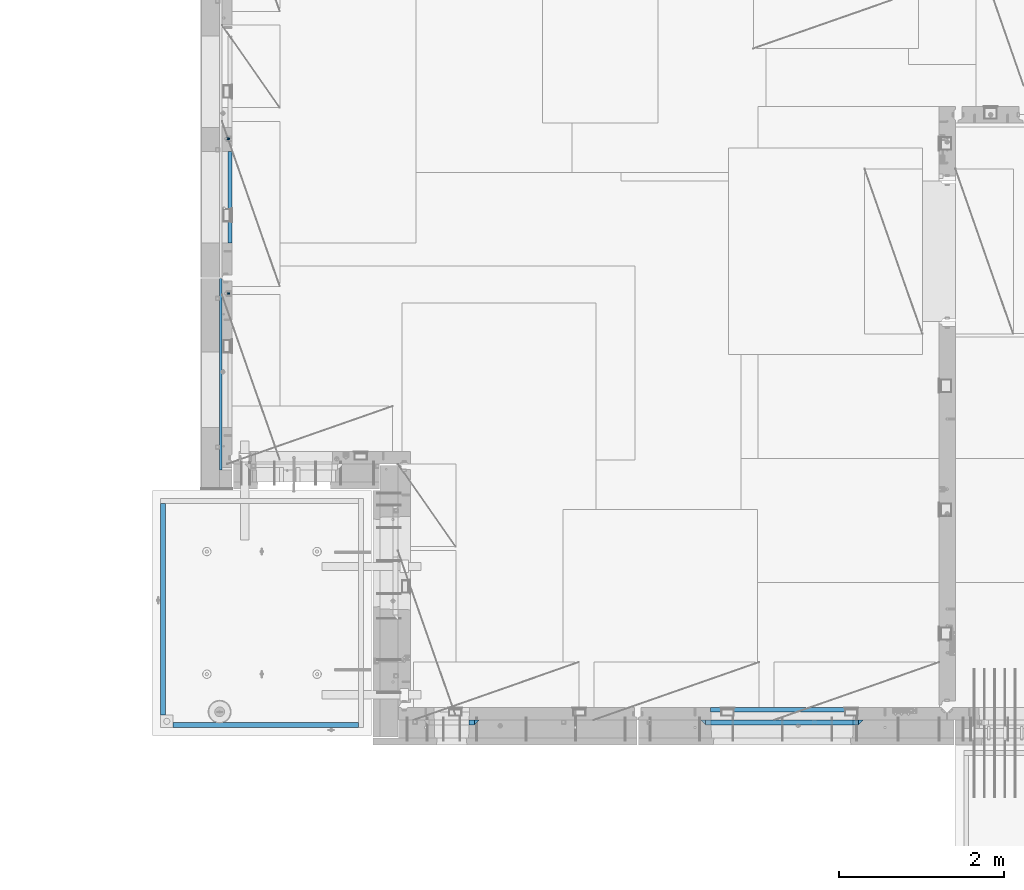
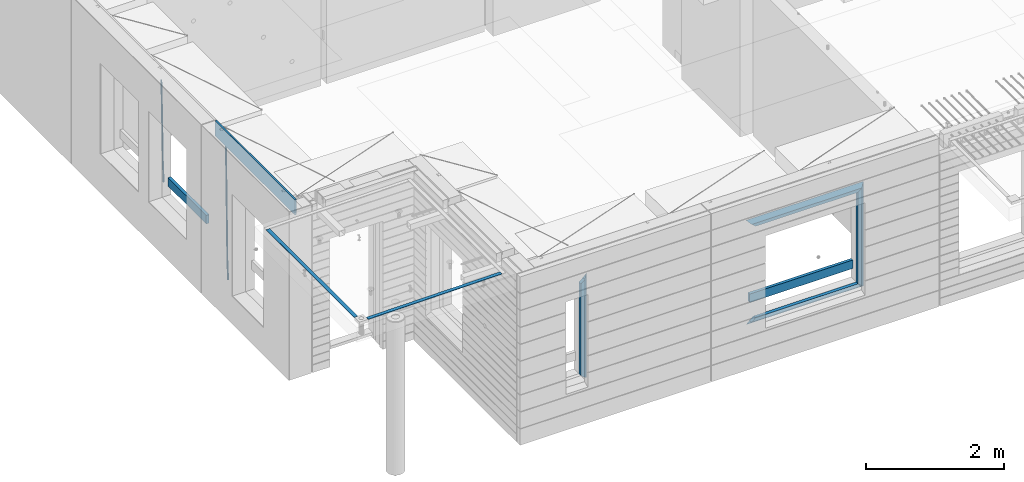
# One storey, part 91 of 352: 15 beams, 5 elements without a shape of their own.
"""IFC2X3 building model written with IfcOpenShell, lengths in millimetres."""

from ifc_helpers import new_model, si_unit, frame, origin_with_axes, place, context, subcontext, project, spatial, faceted_brep, material, type_object, element, aggregate, save


model = new_model("IFC2X3")

# Units and contexts
model_context = context("Model", 3, precision=1e-05, world=origin_with_axes())
body_context = subcontext(model_context, "Body", "Model", "MODEL_VIEW")
ifc_project = project(units=[si_unit("LENGTHUNIT", "METRE", prefix="MILLI"), si_unit("AREAUNIT", "SQUARE_METRE"), si_unit("VOLUMEUNIT", "CUBIC_METRE"), si_unit("MASSUNIT", "GRAM", prefix="KILO"), si_unit("TIMEUNIT", "SECOND"), si_unit("PLANEANGLEUNIT", "RADIAN"), si_unit("SOLIDANGLEUNIT", "STERADIAN"), si_unit("THERMODYNAMICTEMPERATUREUNIT", "DEGREE_CELSIUS"), si_unit("LUMINOUSINTENSITYUNIT", "LUMEN")], contexts=[model_context])

# Site, building, storey
site_placement = place(None, origin_with_axes())
site = spatial("IfcSite", under=ifc_project, at=site_placement, CompositionType="ELEMENT")
building_placement = place(site_placement, origin_with_axes())
building = spatial("IfcBuilding", under=site, at=building_placement, CompositionType="ELEMENT")
storey_placement = place(building_placement, origin_with_axes())
storey = spatial("IfcBuildingStorey", under=building, at=storey_placement, Name="6", CompositionType="ELEMENT", Elevation=0.0)

# Assembly, beam
assembly_1_placement = place(storey_placement, origin_with_axes())
assembly_1 = element("IfcElementAssembly", 1, at=assembly_1_placement, inside=storey, AssemblyPlace="NOTDEFINED", PredefinedType="REINFORCEMENT_UNIT")
ifc_material_1 = material()
beam_type_1 = type_object("IfcBeamType", Name="D20", PredefinedType="NOTDEFINED")
beam_1_placement = place(assembly_1_placement, frame((7964.99984877319, 14888.5021362169, 97590.0), z_axis=(-0.999642804636942, -0.000205726999925762, -0.0267249099902983), x_axis=(-0.0267249099948371, 4.30000201934385e-08, 0.999642825806181)))
beam_1 = element("IfcBeam", 2, at=beam_1_placement, type_object=beam_type_1, material=ifc_material_1, Name="JM20", ObjectType="D20", context=body_context, shape_type="Brep", body=[
    faceted_brep([(0.0, -10.0, 0.0), (-4.19531716033816e-08, -7.07106781186667, -7.07106781187031), (60.4266690400545, -7.0710677960451, -7.07106780570757), (60.4266690441291, -9.99999998418934, 6.15546014159918e-09), (0.0, 0.0, -10.0), (60.426669036824, 1.58106558956206e-08, -9.99999999384454), (4.196772351861e-08, 7.07106781186303, -7.07106781186667), (60.4266690363438, 7.07106782768096, -7.07106780570757), (0.0, 10.0, 0.0), (60.4266690388904, 10.0000000158179, 6.15182216279209e-09), (4.196772351861e-08, 7.07106781185939, 7.07106781185939), (60.4266690429649, 7.07106782768096, 7.07106781802577), (0.0, 0.0, 10.0), (60.4266690461809, 1.58179318532348e-08, 10.0000000061555), (-4.19531716033816e-08, -7.07106781187031, 7.07106781185939), (60.4266690466611, -7.07106779605238, 7.07106781802213), (61.0378400410118, -7.07106779588503, -7.07106780564936), (60.991799419251, -9.99999998403655, 6.21366780251265e-09), (61.0569027789461, 1.5985278878361e-08, -9.99999999378269), (61.0378209396877, 7.07106782784831, -7.07106780564936), (60.9917724058905, 10.0000000159635, 6.21366780251265e-09), (60.9457317841297, 7.07106782781193, 7.0710678180767), (60.9266690461809, 1.59488990902901e-08, 10.0000000062028), (60.9457508854539, -7.07106779591413, 7.0710678180767), (61.6489592143771, -7.07106614513759, -7.06310863441468), (61.5568818710308, -9.9999984576425, 0.00735959856683621), (61.6870830769039, 1.71821739058942e-06, -9.99179257185824), (61.6489210170112, 7.07106947854481, -7.06310888312146), (61.556827851804, 10.0000015422847, 0.00735924683976918), (61.4647505084577, 7.07106922979438, 7.07782747982128), (61.4266266459163, 1.36643211590126e-06, 10.0065114172685), (61.464788705809, -7.07106639389531, 7.07782772852806), (176.543135720174, -7.07075579406956, -5.56673531796696), (176.451058376813, -9.99968810657447, 1.50373291501455), (176.581259582701, 0.000312069292704109, -8.49541925541052), (176.543097522794, 7.07137982961285, -5.56673556667374), (176.451004357587, 10.00031189336, 1.50373256329476), (176.35892701424, 7.07137958085514, 8.57420079627263), (176.320803151699, 0.000311717507429421, 11.5028847337162), (176.358965211621, -7.07075604281999, 8.57420104497578), (177.098753836006, -7.07075429323595, -5.55949898843028), (176.98362511232, -9.99968666800123, 1.510669025065), (177.146421932586, 0.000313595905026887, -8.48805862247536), (177.098706077581, 7.07138133041735, -5.55949936166144), (176.983557571715, 10.0003133318824, 1.51066849724157), (176.868428848029, 7.07138095712435, 8.58083651073321), (176.820760751449, 0.000313067976094317, 11.5093961447819), (176.868476606425, -7.07075466652896, 8.58083688396073), (177.654312950661, -7.07075204110879, -5.54863964998367), (177.516135294456, -9.99968450931192, 1.52107783331303), (177.711524267797, 0.000315886711177882, -8.47701274570863), (177.654255632195, 7.07138358250813, -5.54864021007961), (177.516054233929, 10.0003154905207, 1.5210770412159), (177.377876577739, 7.0713830223176, 8.59079452451624), (177.320665260588, 0.000315094497636892, 11.5191676202448), (177.377933896176, -7.07075260129932, 8.59079508461218), (299.461778333818, -7.07025827596954, -3.16770791544877), (299.323600677439, -9.99919074416357, 3.90200956798253), (299.518989651391, 0.000809651852250681, -6.09608101123195), (299.46172101624, 7.07187734764193, -3.16770847554471), (299.323519618119, 10.0008092556727, 3.90200877589086), (299.18534196174, 7.07187678747687, 10.971726259324), (299.128130644167, 0.000808859655080596, 13.9000993551072), (299.185399279333, -7.07025883613824, 10.9717268194163), (300.005099199436, -7.07025607348805, -3.15708779472698), (299.971788958996, -9.99918809853989, 3.91467979818117), (300.018894160545, 0.00081167833377549, -6.08630953626562), (300.005085253739, 7.07187955030167, -3.15708750704471), (299.971753863239, 10.0008119014747, 3.91467990454839), (299.93844362146, 7.0718798403559, 10.9864468987271), (299.924648660366, 0.000812088532256894, 13.9156686402657), (299.938457567187, -7.07025578343564, 10.9864466110448), (300.548496018673, -7.07025720445017, -3.16258750978159), (300.620052478174, -9.9991894658433, 3.90811820064846), (300.518868553889, 0.000810637746326393, -6.09136977328126), (300.548525450897, 7.07187841925042, -3.16258766112878), (300.620094101629, 10.000810534113, 3.90811798661343), (300.69165056113, 7.07187827271991, 10.9788236970453), (300.721278025885, 0.000810430521596572, 13.907605960545), (300.691621128892, -7.07025735098068, 10.9788238483907), (1693.63216510082, -7.07315660432141, -17.2619766794614), (1693.70372156033, -10.0020888657109, -10.1912709690314), (1693.60253763606, -0.00208876212127507, -20.1907589429611), (1693.63219453306, 7.068979019381, -17.2619768308086), (1693.7037631838, 9.9979111342418, -10.1912711830664), (1693.77531964328, 7.06897887284867, -3.12056547263455), (1693.80494710806, -0.00208896934782388, -0.191783209134883), (1693.77529021105, -7.0731567508501, -3.12056532128736), (1694.29779868275, -7.07315798969103, -17.2687135518572), (1694.26743251897, -10.0020900389554, -10.1969762833342), (1694.34857500881, -0.00209031483609579, -20.1983095815103), (1694.39001741401, 7.06897744213711, -17.2696467503938), (1694.39784949942, 9.99790968965317, -10.1982960253627), (1694.36748333565, 7.06897764038877, -3.12655875683777), (1694.3167070096, -0.00209003446616407, -0.196962727188293), (1694.2752646044, -7.07315779143937, -3.125625558303), (1694.96335083364, -7.08183692566672, -17.2598557114488), (1694.83107451542, -10.0094400457037, -10.1894747662172), (1695.09452111425, -0.0118176043979474, -20.1883817771341), (1695.14774758583, 7.05909648594388, -17.259562111758), (1695.09185090323, 9.98885976961174, -10.1890595535533), (1694.95957458501, 7.0612566495729, -3.11867860832172), (1694.82840430441, -0.00876267169223865, -0.190152542638316), (1694.77517783281, -7.07967676203589, -3.11897220801256), (1716.74088258609, -7.36582038739652, -16.9700183177756), (1716.60860626785, -10.2934235074299, -9.8996373725422), (1716.87205286669, -0.295801066125932, -19.898544383459), (1716.92527933829, 6.77511302421226, -16.9697247180848), (1716.86938265568, 9.70487630788193, -9.89922215988008), (1716.73710633747, 6.77727318784673, -2.82884121464849), (1716.60593605686, -0.292746133423861, 0.0996848510367272), (1716.55270958526, -7.36366022376751, -2.82913481433934), (1717.37632925155, -7.37410674169405, -16.9615611515819), (1717.2686961548, -10.302031214369, -9.89085222946233), (1717.45037731848, -0.30334253509136, -19.8908474573927), (1717.44746400231, 6.76830362954752, -16.96277495703), (1717.36929588411, 9.6983573372836, -9.89256880959147), (1717.26166278738, 6.77043286460685, -2.82185988747187), (1717.18761472043, -0.300331341994024, 0.107426418340765), (1717.1905280366, -7.3719775066329, -2.82064608202199), (1718.0118297398, -7.37223067542982, -16.9532990407679), (1717.92884180055, -10.3000626540106, -9.8822625771154), (1718.02875100763, -0.301644694996867, -19.8833453418993), (1717.96969335481, 6.76984191386691, -16.9560200956876), (1717.86925195342, 9.69984820183527, -9.88611072988533), (1717.78626401415, 6.77201622325447, -2.81507426623284), (1717.76934274634, -0.298569757178484, 0.114972034898528), (1717.82840039914, -7.37005636604226, -2.81235321131317), (1818.03261514839, -7.07396855575644, -15.6559248891263), (1817.94962720915, -10.0018005343409, -8.58488842547376), (1818.04953641623, -0.00338257532712305, -18.5859711902594), (1817.99047876342, 7.06810403353848, -15.6586459440477), (1817.89003736203, 9.99811032150683, -8.58873657824552), (1817.80704942276, 7.07027834292421, -1.51770011459121), (1817.79012815493, -0.00030763750692131, 1.41234618654016), (1817.84918580775, -7.07179424637252, -1.51497905967153)], [[[0, 1, 2, 3]], [[1, 4, 5, 2]], [[4, 6, 7, 5]], [[6, 8, 9, 7]], [[8, 10, 11, 9]], [[10, 12, 13, 11]], [[12, 14, 15, 13]], [[14, 0, 3, 15]], [[14, 12, 10, 8, 6, 4, 1, 0]], [[3, 2, 16, 17]], [[2, 5, 18, 16]], [[5, 7, 19, 18]], [[7, 9, 20, 19]], [[9, 11, 21, 20]], [[11, 13, 22, 21]], [[13, 15, 23, 22]], [[15, 3, 17, 23]], [[17, 16, 24, 25]], [[16, 18, 26, 24]], [[18, 19, 27, 26]], [[19, 20, 28, 27]], [[20, 21, 29, 28]], [[21, 22, 30, 29]], [[22, 23, 31, 30]], [[23, 17, 25, 31]], [[25, 24, 32, 33]], [[24, 26, 34, 32]], [[26, 27, 35, 34]], [[27, 28, 36, 35]], [[28, 29, 37, 36]], [[29, 30, 38, 37]], [[30, 31, 39, 38]], [[31, 25, 33, 39]], [[33, 32, 40, 41]], [[32, 34, 42, 40]], [[34, 35, 43, 42]], [[35, 36, 44, 43]], [[36, 37, 45, 44]], [[37, 38, 46, 45]], [[38, 39, 47, 46]], [[39, 33, 41, 47]], [[41, 40, 48, 49]], [[40, 42, 50, 48]], [[42, 43, 51, 50]], [[43, 44, 52, 51]], [[44, 45, 53, 52]], [[45, 46, 54, 53]], [[46, 47, 55, 54]], [[47, 41, 49, 55]], [[49, 48, 56, 57]], [[48, 50, 58, 56]], [[50, 51, 59, 58]], [[51, 52, 60, 59]], [[52, 53, 61, 60]], [[53, 54, 62, 61]], [[54, 55, 63, 62]], [[55, 49, 57, 63]], [[57, 56, 64, 65]], [[56, 58, 66, 64]], [[58, 59, 67, 66]], [[59, 60, 68, 67]], [[60, 61, 69, 68]], [[61, 62, 70, 69]], [[62, 63, 71, 70]], [[63, 57, 65, 71]], [[65, 64, 72, 73]], [[64, 66, 74, 72]], [[66, 67, 75, 74]], [[67, 68, 76, 75]], [[68, 69, 77, 76]], [[69, 70, 78, 77]], [[70, 71, 79, 78]], [[71, 65, 73, 79]], [[73, 72, 80, 81]], [[72, 74, 82, 80]], [[74, 75, 83, 82]], [[75, 76, 84, 83]], [[76, 77, 85, 84]], [[77, 78, 86, 85]], [[78, 79, 87, 86]], [[79, 73, 81, 87]], [[81, 80, 88, 89]], [[80, 82, 90, 88]], [[82, 83, 91, 90]], [[83, 84, 92, 91]], [[84, 85, 93, 92]], [[85, 86, 94, 93]], [[86, 87, 95, 94]], [[87, 81, 89, 95]], [[89, 88, 96, 97]], [[88, 90, 98, 96]], [[90, 91, 99, 98]], [[91, 92, 100, 99]], [[92, 93, 101, 100]], [[93, 94, 102, 101]], [[94, 95, 103, 102]], [[95, 89, 97, 103]], [[97, 96, 104, 105]], [[96, 98, 106, 104]], [[98, 99, 107, 106]], [[99, 100, 108, 107]], [[100, 101, 109, 108]], [[101, 102, 110, 109]], [[102, 103, 111, 110]], [[103, 97, 105, 111]], [[105, 104, 112, 113]], [[104, 106, 114, 112]], [[106, 107, 115, 114]], [[107, 108, 116, 115]], [[108, 109, 117, 116]], [[109, 110, 118, 117]], [[110, 111, 119, 118]], [[111, 105, 113, 119]], [[113, 112, 120, 121]], [[112, 114, 122, 120]], [[114, 115, 123, 122]], [[115, 116, 124, 123]], [[116, 117, 125, 124]], [[117, 118, 126, 125]], [[118, 119, 127, 126]], [[119, 113, 121, 127]], [[121, 120, 128, 129]], [[120, 122, 130, 128]], [[122, 123, 131, 130]], [[123, 124, 132, 131]], [[124, 125, 133, 132]], [[125, 126, 134, 133]], [[126, 127, 135, 134]], [[127, 121, 129, 135]], [[130, 131, 132, 133, 134, 135, 129, 128]]]),
])

assembly_2_placement = place(storey_placement, origin_with_axes())
assembly_2 = element("IfcElementAssembly", 3, at=assembly_2_placement, inside=storey, AssemblyPlace="NOTDEFINED", PredefinedType="REINFORCEMENT_UNIT")
beam_2_placement = place(assembly_2_placement, frame((7964.99972837123, 13015.0021274634, 96990.0), z_axis=(-0.999642804636942, -0.000205726999925762, -0.0267249099902983), x_axis=(-0.0267249099948371, 4.30000201934385e-08, 0.999642825806181)))
beam_2 = element("IfcBeam", 4, at=beam_2_placement, type_object=beam_type_1, material=ifc_material_1, Name="JM20", ObjectType="D20", context=body_context, shape_type="Brep", body=[
    faceted_brep([(0.0, -10.0, 0.0), (-4.19531716033816e-08, -7.07106781186667, -7.07106781187031), (60.4266690400545, -7.0710677960451, -7.07106780570757), (60.4266690441291, -9.99999998418934, 6.15546014159918e-09), (0.0, 0.0, -10.0), (60.426669036824, 1.58106558956206e-08, -9.99999999384454), (4.196772351861e-08, 7.07106781186303, -7.07106781186667), (60.4266690363438, 7.07106782768096, -7.07106780570757), (0.0, 10.0, 0.0), (60.4266690388904, 10.0000000158179, 6.15182216279209e-09), (4.196772351861e-08, 7.07106781185939, 7.07106781185939), (60.4266690429649, 7.07106782768096, 7.07106781802577), (0.0, 0.0, 10.0), (60.4266690461809, 1.58179318532348e-08, 10.0000000061555), (-4.19531716033816e-08, -7.07106781187031, 7.07106781185939), (60.4266690466611, -7.07106779605238, 7.07106781802213), (61.0378400410118, -7.07106779588503, -7.07106780564936), (60.991799419251, -9.99999998403655, 6.21366780251265e-09), (61.0569027789461, 1.5985278878361e-08, -9.99999999378269), (61.0378209396877, 7.07106782784831, -7.07106780564936), (60.9917724058905, 10.0000000159635, 6.21366780251265e-09), (60.9457317841297, 7.07106782781193, 7.0710678180767), (60.9266690461809, 1.59488990902901e-08, 10.0000000062028), (60.9457508854539, -7.07106779591413, 7.0710678180767), (61.6489592143771, -7.07106614513759, -7.06310863441468), (61.5568818710308, -9.9999984576425, 0.00735959856683621), (61.6870830769039, 1.71821739058942e-06, -9.99179257185824), (61.6489210170112, 7.07106947854481, -7.06310888312146), (61.556827851804, 10.0000015422847, 0.00735924683976918), (61.4647505084577, 7.07106922979438, 7.07782747982128), (61.4266266459163, 1.36643211590126e-06, 10.0065114172685), (61.464788705809, -7.07106639389531, 7.07782772852806), (176.543135720174, -7.07075579406956, -5.56673531796696), (176.451058376813, -9.99968810657447, 1.50373291501455), (176.581259582701, 0.000312069292704109, -8.49541925541052), (176.543097522794, 7.07137982961285, -5.56673556667374), (176.451004357587, 10.00031189336, 1.50373256329476), (176.35892701424, 7.07137958085514, 8.57420079627263), (176.320803151699, 0.000311717507429421, 11.5028847337162), (176.358965211621, -7.07075604281999, 8.57420104497578), (177.098753836006, -7.07075429323595, -5.55949898843028), (176.98362511232, -9.99968666800123, 1.510669025065), (177.146421932586, 0.000313595905026887, -8.48805862247536), (177.098706077581, 7.07138133041735, -5.55949936166144), (176.983557571715, 10.0003133318824, 1.51066849724157), (176.868428848029, 7.07138095712435, 8.58083651073321), (176.820760751449, 0.000313067976094317, 11.5093961447819), (176.868476606425, -7.07075466652896, 8.58083688396073), (177.654312950661, -7.07075204110879, -5.54863964998367), (177.516135294456, -9.99968450931192, 1.52107783331303), (177.711524267797, 0.000315886711177882, -8.47701274570863), (177.654255632195, 7.07138358250813, -5.54864021007961), (177.516054233929, 10.0003154905207, 1.5210770412159), (177.377876577739, 7.0713830223176, 8.59079452451624), (177.320665260588, 0.000315094497636892, 11.5191676202448), (177.377933896176, -7.07075260129932, 8.59079508461218), (299.436796249574, -7.07025836271714, -3.1681962331204), (299.298618593355, -9.99919083092027, 3.90152125031091), (299.494007566798, 0.000809565110102994, -6.09656932889993), (299.436738931283, 7.07187726089978, -3.16819679320906), (299.298537533061, 10.0008091689197, 3.90152045822106), (299.160359876842, 7.07187670072017, 10.9712379416487), (299.103148559603, 0.000808772889286047, 13.8996110374392), (299.160417195119, -7.07025892290039, 10.9712385017483), (299.98743051647, -7.07025613056248, -3.15743315966392), (299.971788958996, -9.99918809853989, 3.91467979818117), (299.993912075952, 0.000811591617093654, -6.08679785393178), (299.987423933868, 7.07187949325817, -3.1574327280432), (299.971753863239, 10.0008119014747, 3.91467990454839), (299.95611230444, 7.07187992653053, 10.9867922621015), (299.949630744944, 0.000812204350950196, 13.9161569563694), (299.956118887014, -7.07025569729012, 10.9867918304735), (300.538107039494, -7.07025785017686, -3.16575821840888), (300.644985195438, -9.99919020432935, 3.90450175465594), (300.493854948218, 0.000810030429420294, -6.09435592770024), (300.538151196495, 7.071877773491, -3.16575855385963), (300.645047642858, 10.0008097955724, 3.90450128024895), (300.751925798773, 7.07187744142357, 10.9747612533101), (300.796177890064, 0.000809560813650023, 13.9033589625978), (300.751881641787, -7.07025818224065, 10.9747615887682), (2293.36490490142, -7.07648090940347, -33.2930642912361), (2293.47178305736, -10.0054132635523, -26.2228043181785), (2293.32065281013, -0.00541302880083094, -36.2216620005347), (2293.36494905842, 7.06565471425711, -33.2930646266868), (2293.47184550477, 9.99458673634581, -26.2228047925819), (2293.57872366071, 7.06565438219332, -19.1525448195243), (2293.62297575199, -0.00541349841296324, -16.2239471102366), (2293.57867950371, -7.0764812414709, -19.1525444840736), (2294.0658245362, -7.07648309818615, -33.3036607065333), (2294.05312277409, -10.0054150789219, -26.2315929392535), (2294.10928714235, -0.00541549149056664, -36.2335844756526), (2294.15805078732, 7.06565223761572, -33.3050546393533), (2294.18355038921, 9.99458451388637, -26.2335642579346), (2294.17084862708, 7.06565253314329, -19.1614964906439), (2294.12738602093, -0.00541507354500936, -16.2315727215355), (2294.07862237596, -7.07648280265857, -19.1601025578348), (2294.76670261032, -7.08562269121467, -33.294332712383), (2294.63442802057, -10.0129954178956, -26.2238563411993), (2294.89787471293, -0.0156988342423574, -36.2230891548279), (2294.95110548967, 7.05531064255774, -33.2944998654275), (2294.89521307347, 9.98530428734011, -26.2240927312887), (2294.76293848372, 7.0579315606592, -19.1536163601049), (2294.63176638114, -0.0119922963167483, -16.2248599176673), (2294.57853560438, -7.08300177311321, -19.1534492070678), (2316.52657204497, -7.36937582653991, -33.0047303660212), (2316.39429745522, -10.2967485532172, -25.9342539948302), (2316.65774414754, -0.299451969567599, -35.9334868084661), (2316.7109749243, 6.7715575072325, -33.0048975190657), (2316.65508250811, 9.70155115201487, -25.9344903849269), (2316.52280791836, 6.7741784253376, -18.8640140137468), (2316.39163581574, -0.295745431634714, -15.9352575713092), (2316.33840503903, -7.36675490843481, -18.863846860706), (2317.16202064224, -7.37766220584308, -32.9962731735213), (2317.05438744847, -10.3053562613532, -25.9254688497131), (2317.23607125619, -0.306993473008333, -35.925789846493), (2317.23316144495, 6.76474808850253, -32.9979477328052), (2317.15499573652, 9.6950321815566, -25.9278370341635), (2317.04736254275, 6.7673381260538, -18.8570327103698), (2316.97331192881, -0.303330606784584, -15.9275160373909), (2316.97622174003, -7.37507216829545, -18.8553581510787), (2317.79752306276, -7.37578610372293, -32.9880110666527), (2317.71453320107, -10.3033876998124, -25.9168792378296), (2317.81444760226, -0.305295583297266, -35.918287695793), (2317.75539265381, 6.76628640723357, -32.9911928173897), (2317.65495180529, 9.69652304524061, -25.9213789128698), (2317.5719619436, 6.76892144914746, -18.8502470840467), (2317.55503740412, -0.301569071270933, -15.9199704549137), (2317.61409235255, -7.3731510618054, -18.847065333317), (2417.8183084176, -7.07752398473531, -31.6906369377139), (2417.73531855589, -10.0051255808248, -24.6195051088798), (2417.83523295709, -0.007033464313281, -34.6209135668432), (2417.77617800863, 7.06454852621755, -31.6938186884508), (2417.67573716014, 9.99478516423187, -24.6240047839383), (2417.59274729842, 7.06718356813872, -17.5528729551006), (2417.57582275895, -0.00330695228694822, -14.6225963259749), (2417.6348777074, -7.07488894281778, -17.5496912043673)], [[[0, 1, 2, 3]], [[1, 4, 5, 2]], [[4, 6, 7, 5]], [[6, 8, 9, 7]], [[8, 10, 11, 9]], [[10, 12, 13, 11]], [[12, 14, 15, 13]], [[14, 0, 3, 15]], [[14, 12, 10, 8, 6, 4, 1, 0]], [[3, 2, 16, 17]], [[2, 5, 18, 16]], [[5, 7, 19, 18]], [[7, 9, 20, 19]], [[9, 11, 21, 20]], [[11, 13, 22, 21]], [[13, 15, 23, 22]], [[15, 3, 17, 23]], [[17, 16, 24, 25]], [[16, 18, 26, 24]], [[18, 19, 27, 26]], [[19, 20, 28, 27]], [[20, 21, 29, 28]], [[21, 22, 30, 29]], [[22, 23, 31, 30]], [[23, 17, 25, 31]], [[25, 24, 32, 33]], [[24, 26, 34, 32]], [[26, 27, 35, 34]], [[27, 28, 36, 35]], [[28, 29, 37, 36]], [[29, 30, 38, 37]], [[30, 31, 39, 38]], [[31, 25, 33, 39]], [[33, 32, 40, 41]], [[32, 34, 42, 40]], [[34, 35, 43, 42]], [[35, 36, 44, 43]], [[36, 37, 45, 44]], [[37, 38, 46, 45]], [[38, 39, 47, 46]], [[39, 33, 41, 47]], [[41, 40, 48, 49]], [[40, 42, 50, 48]], [[42, 43, 51, 50]], [[43, 44, 52, 51]], [[44, 45, 53, 52]], [[45, 46, 54, 53]], [[46, 47, 55, 54]], [[47, 41, 49, 55]], [[49, 48, 56, 57]], [[48, 50, 58, 56]], [[50, 51, 59, 58]], [[51, 52, 60, 59]], [[52, 53, 61, 60]], [[53, 54, 62, 61]], [[54, 55, 63, 62]], [[55, 49, 57, 63]], [[57, 56, 64, 65]], [[56, 58, 66, 64]], [[58, 59, 67, 66]], [[59, 60, 68, 67]], [[60, 61, 69, 68]], [[61, 62, 70, 69]], [[62, 63, 71, 70]], [[63, 57, 65, 71]], [[65, 64, 72, 73]], [[64, 66, 74, 72]], [[66, 67, 75, 74]], [[67, 68, 76, 75]], [[68, 69, 77, 76]], [[69, 70, 78, 77]], [[70, 71, 79, 78]], [[71, 65, 73, 79]], [[73, 72, 80, 81]], [[72, 74, 82, 80]], [[74, 75, 83, 82]], [[75, 76, 84, 83]], [[76, 77, 85, 84]], [[77, 78, 86, 85]], [[78, 79, 87, 86]], [[79, 73, 81, 87]], [[81, 80, 88, 89]], [[80, 82, 90, 88]], [[82, 83, 91, 90]], [[83, 84, 92, 91]], [[84, 85, 93, 92]], [[85, 86, 94, 93]], [[86, 87, 95, 94]], [[87, 81, 89, 95]], [[89, 88, 96, 97]], [[88, 90, 98, 96]], [[90, 91, 99, 98]], [[91, 92, 100, 99]], [[92, 93, 101, 100]], [[93, 94, 102, 101]], [[94, 95, 103, 102]], [[95, 89, 97, 103]], [[97, 96, 104, 105]], [[96, 98, 106, 104]], [[98, 99, 107, 106]], [[99, 100, 108, 107]], [[100, 101, 109, 108]], [[101, 102, 110, 109]], [[102, 103, 111, 110]], [[103, 97, 105, 111]], [[105, 104, 112, 113]], [[104, 106, 114, 112]], [[106, 107, 115, 114]], [[107, 108, 116, 115]], [[108, 109, 117, 116]], [[109, 110, 118, 117]], [[110, 111, 119, 118]], [[111, 105, 113, 119]], [[113, 112, 120, 121]], [[112, 114, 122, 120]], [[114, 115, 123, 122]], [[115, 116, 124, 123]], [[116, 117, 125, 124]], [[117, 118, 126, 125]], [[118, 119, 127, 126]], [[119, 113, 121, 127]], [[121, 120, 128, 129]], [[120, 122, 130, 128]], [[122, 123, 131, 130]], [[123, 124, 132, 131]], [[124, 125, 133, 132]], [[125, 126, 134, 133]], [[126, 127, 135, 134]], [[127, 121, 129, 135]], [[130, 131, 132, 133, 134, 135, 129, 128]]]),
])

assembly_3_placement = place(storey_placement, origin_with_axes())
assembly_3 = element("IfcElementAssembly", 5, at=assembly_3_placement, inside=storey, AssemblyPlace="NOTDEFINED", PredefinedType="REINFORCEMENT_UNIT")
ifc_material_2 = material(Name="TIMBER/T24")
beam_type_2 = type_object("IfcBeamType", PredefinedType="NOTDEFINED")
beam_3_placement = place(assembly_3_placement, frame((13795.0009023501, 7974.99972412935, 97685.0), z_axis=(0.0, 0.0, 1.0), x_axis=(1.0, 0.0, 0.0)))
beam_3 = element("IfcBeam", 6, at=beam_3_placement, type_object=beam_type_2, material=ifc_material_2, context=body_context, shape_type="Brep", body=[
    faceted_brep([(-3.63797880709171e-12, 24.9999999999964, -75.0), (-3.63797880709171e-12, 24.9999999999964, 75.0), (1730.0, 25.0, 75.0), (1730.0, 25.0, -75.0), (0.0, -25.0000000000073, 75.0), (1730.0, -25.0, 75.0), (0.0, -25.0000000000073, -75.0), (1730.0, -25.0, -75.0)], [[[0, 1, 2, 3]], [[1, 4, 5, 2]], [[4, 6, 7, 5]], [[6, 0, 3, 7]], [[5, 7, 3, 2]], [[6, 4, 1, 0]]]),
])

# Beam
beam_4_placement = place(assembly_1_placement, frame((7975.00000026382, 14735.0004107749, 97685.0), z_axis=(0.0, 0.0, 1.0), x_axis=(0.0, -1.0, 0.0)))
beam_4 = element("IfcBeam", 7, at=beam_4_placement, type_object=beam_type_2, material=ifc_material_2, context=body_context, shape_type="Brep", body=[
    faceted_brep([(-3.63797880709171e-12, 24.9999999999964, -75.0), (-3.63797880709171e-12, 24.9999999999964, 75.0), (1110.0, 24.9999999999964, 75.0), (1110.0, 24.9999999999964, -75.0), (0.0, -25.0000000000073, 75.0), (1110.0, -25.0000000000073, 75.0), (0.0, -25.0000000000073, -75.0), (1110.0, -25.0000000000073, -75.0)], [[[0, 1, 2, 3]], [[1, 4, 5, 2]], [[4, 6, 7, 5]], [[6, 0, 3, 7]], [[5, 7, 3, 2]], [[6, 4, 1, 0]]]),
])

aggregate(assembly_1, [beam_1, beam_4])

# Assembly, beams
assembly_4_placement = place(storey_placement, origin_with_axes())
assembly_4 = element("IfcElementAssembly", 8, at=assembly_4_placement, inside=storey, AssemblyPlace="NOTDEFINED", PredefinedType="REINFORCEMENT_UNIT")
ifc_material_3 = material(Name="CONCRETE/Concrete_Undefined")
beam_type_3 = type_object("IfcBeamType", PredefinedType="NOTDEFINED")
beam_5_placement = place(assembly_4_placement, frame((7164.89422591706, 10470.0076633258, 99701.6030105556), z_axis=(0.0, -1.17599999975856e-06, 0.999999999999309), x_axis=(4.13430000058061e-05, -0.999999999144687, -1.176000002514e-06)))
beam_5 = element("IfcBeam", 9, at=beam_5_placement, type_object=beam_type_3, material=ifc_material_3, context=body_context, shape_type="Brep", body=[
    faceted_brep([(2.5465851649642e-11, 29.9999999999982, -4.99999999998545), (-2.91038304567337e-11, 29.9999999999982, 5.0), (2560.00574992944, 30.0000000000009, 5.00000000001455), (2560.00574992944, 30.0, -5.0), (-2.5465851649642e-11, -30.0000000000018, 5.0), (2560.00574992944, -29.9999999999991, 5.00000000001455), (2.72848410531878e-11, -30.0000000000018, -4.99999999998545), (2560.00574992944, -30.0, -5.0)], [[[0, 1, 2, 3]], [[1, 4, 5, 2]], [[4, 6, 7, 5]], [[6, 0, 3, 7]], [[5, 7, 3, 2]], [[6, 4, 1, 0]]]),
])
beam_6_placement = place(assembly_4_placement, frame((9529.67128970205, 7789.99860988154, 99725.2790473986), z_axis=(-0.00918361699724776, 4.9999998721906e-09, 0.999957829700257), x_axis=(-0.999957829700102, 5.55999999934641e-07, -0.00918361699724765)))
beam_6 = element("IfcBeam", 10, at=beam_6_placement, type_object=beam_type_3, material=ifc_material_3, context=body_context, shape_type="Brep", body=[
    faceted_brep([(2.5465851649642e-11, 29.9999999999982, -4.99999999998545), (-2.91038304567337e-11, 29.9999999999982, 5.0), (2244.79868782777, 30.0, 5.00000000001455), (2244.79868782778, 30.0, -4.99999999995634), (-2.5465851649642e-11, -30.0000000000018, 5.0), (2244.79868782778, -30.0000000000009, 5.00000000001455), (2.72848410531878e-11, -30.0000000000018, -4.99999999998545), (2244.79868782778, -30.0, -4.9999999999709)], [[[0, 1, 2, 3]], [[1, 4, 5, 2]], [[4, 6, 7, 5]], [[6, 0, 3, 7]], [[5, 7, 3, 2]], [[6, 4, 1, 0]]]),
])
aggregate(assembly_4, [beam_5, beam_6])

# Assembly, beam
assembly_5_placement = place(storey_placement, origin_with_axes())
assembly_5 = element("IfcElementAssembly", 11, at=assembly_5_placement, inside=storey, AssemblyPlace="NOTDEFINED", PredefinedType="REINFORCEMENT_UNIT")
ifc_material_4 = material(Name="CONCRETE/C25/30")
beam_type_4 = type_object("IfcBeamType", PredefinedType="NOTDEFINED")
beam_7_placement = place(assembly_5_placement, frame((10964.9994055559, 7820.0, 99175.0), z_axis=(-1.0, 3.00000001838171e-08, 0.0), x_axis=(0.0, 0.0, -1.0)))
beam_7 = element("IfcBeam", 12, at=beam_7_placement, type_object=beam_type_4, material=ifc_material_4, Name="SK", context=body_context, shape_type="Brep", body=[
    faceted_brep([(60.0000000000073, 30.0, 30.0), (0.0, -30.0, -30.0), (60.0000000000073, -30.0, 30.0), (1855.0, -30.0, -30.0), (1795.00000000001, -30.0, 30.0), (1795.00000000001, 30.0, 30.0)], [[[0, 1, 2]], [[3, 4, 2, 1]], [[4, 5, 0, 2]], [[5, 3, 1, 0]], [[4, 3, 5]]]),
])

# Beam
beam_8_placement = place(assembly_3_placement, frame((13675.0004364773, 7820.0, 99145.0), z_axis=(0.0, 0.0, -1.0), x_axis=(1.0, 0.0, 0.0)))
beam_8 = element("IfcBeam", 13, at=beam_8_placement, type_object=beam_type_4, material=ifc_material_4, Name="SK", context=body_context, shape_type="Brep", body=[
    faceted_brep([(60.0000000000073, 30.0, 30.0), (0.0, -30.0, -30.0), (60.0000000000073, -30.0, 30.0), (1969.99980926514, -30.0, -30.0), (1909.99980926512, -30.0, 30.0), (1909.99980926512, 30.0, 30.0)], [[[0, 1, 2]], [[2, 1, 3, 4]], [[0, 2, 4, 5]], [[1, 0, 5, 3]], [[4, 3, 5]]]),
])

beam_9_placement = place(assembly_3_placement, frame((13735.0004364773, 7820.0, 99085.0), z_axis=(0.0, 0.0, -1.0), x_axis=(1.0, 0.0, 0.0)))
beam_9 = element("IfcBeam", 14, at=beam_9_placement, type_object=beam_type_4, material=ifc_material_4, Name="SK", context=body_context, shape_type="Brep", body=[
    faceted_brep([(1785.94575521108, -30.0, 24.0540540540533), (1784.32413358946, 30.0, 25.6756756756804), (65.6754849408117, 30.0, 25.6756756756804), (64.05386331919, -30.0, 24.0540540540533), (65.6754849408117, 30.0, 26.2932727940788), (64.05386331919, -30.0, 24.9033114044141), (0.0, -30.0, -30.0), (0.0, 30.0, -30.0), (1849.99980926514, -30.0, -30.0), (1785.94575521108, -30.0, 24.9034748914273), (1784.32413358946, 30.0, 26.293436281092), (1849.99980926514, 30.0, -30.0)], [[[0, 1, 2, 3]], [[3, 2, 4, 5]], [[6, 5, 4, 7]], [[0, 3, 5, 6, 8, 9]], [[1, 0, 9, 10]], [[7, 4, 2, 1, 10, 11]], [[6, 7, 11, 8]], [[10, 9, 8, 11]]]),
])

beam_10_placement = place(assembly_3_placement, frame((15615.0002457424, 7820.0, 99175.0), z_axis=(-1.0, 3.00000001838171e-08, 0.0), x_axis=(0.0, 0.0, -1.0)))
beam_10 = element("IfcBeam", 15, at=beam_10_placement, type_object=beam_type_4, material=ifc_material_4, Name="SK", context=body_context, shape_type="Brep", body=[
    faceted_brep([(60.0000000000073, 30.0, 30.0), (0.0, -30.0, -30.0), (60.0000000000073, -30.0, 30.0), (1855.0, -30.0, -30.0), (1795.00000000001, -30.0, 30.0), (1795.00000000001, 30.0, 30.0)], [[[0, 1, 2]], [[3, 4, 2, 1]], [[4, 5, 0, 2]], [[5, 3, 1, 0]], [[4, 3, 5]]]),
])

beam_11_placement = place(assembly_3_placement, frame((15645.0002457424, 7820.0, 97350.0), z_axis=(0.0, 0.0, 1.0), x_axis=(-1.0, 3.00000001838171e-08, 0.0)))
beam_11 = element("IfcBeam", 16, at=beam_11_placement, type_object=beam_type_4, material=ifc_material_4, Name="SK", context=body_context, shape_type="Brep", body=[
    faceted_brep([(1909.99980926512, -30.0, 30.0), (1969.99980926514, -30.0, -30.0), (1909.99980926512, 30.0, 30.0), (0.0, -30.0, -30.0), (60.0000000000073, 30.0, 30.0), (60.0000000000073, -30.0, 30.0)], [[[0, 1, 2]], [[3, 4, 2, 1]], [[4, 5, 0, 2]], [[5, 3, 1, 0]], [[4, 3, 5]]]),
])

beam_12_placement = place(assembly_3_placement, frame((15585.0002457424, 7820.0, 97410.0), z_axis=(0.0, 0.0, 1.0), x_axis=(-1.0, 3.00000001838171e-08, 0.0)))
beam_12 = element("IfcBeam", 17, at=beam_12_placement, type_object=beam_type_4, material=ifc_material_4, Name="SK", context=body_context, shape_type="Brep", body=[
    faceted_brep([(1785.94594594595, -30.0, 24.0540540540533), (1784.32432432433, 30.0, 25.6756756756804), (65.6756756756768, 30.0, 25.6756756756804), (64.0540540540533, -30.0, 24.0540540540533), (1785.94594594595, -30.0, 24.9033114043996), (1784.32432432433, 30.0, 26.2932727940788), (1849.99980926514, -30.0, -30.0), (1849.99980926514, 30.0, -30.0), (0.0, -30.0, -30.0), (0.0, 30.0, -30.0), (65.6756756756768, 30.0, 26.293436281092), (64.0540540540533, -30.0, 24.9034748914419)], [[[0, 1, 2, 3]], [[1, 0, 4, 5]], [[6, 7, 5, 4]], [[8, 9, 7, 6]], [[2, 1, 5, 7, 9, 10]], [[3, 2, 10, 11]], [[6, 4, 0, 3, 11, 8]], [[8, 11, 10, 9]]]),
])

beam_type_5 = type_object("IfcBeamType", PredefinedType="NOTDEFINED")
beam_13_placement = place(assembly_5_placement, frame((10899.9994055559, 7820.0, 99115.0), z_axis=(-1.0, 3.00000001838171e-08, 0.0), x_axis=(0.0, 0.0, -1.0)))
beam_13 = element("IfcBeam", 18, at=beam_13_placement, type_object=beam_type_5, material=ifc_material_4, Name="SK", context=body_context, shape_type="Brep", body=[
    faceted_brep([(0.0, -30.0, -35.0), (54.9034748914273, -30.0, 29.0540540540533), (56.2934362811066, 30.0, 30.6756756756768), (0.0, 30.0, -35.0), (1735.0, -30.0, -35.0), (1680.09652510857, -30.0, 29.0540540540533), (1678.70656371891, 30.0, 30.6756756756768), (1735.0, 30.0, -35.0)], [[[0, 1, 2, 3]], [[1, 0, 4, 5]], [[2, 1, 5, 6]], [[3, 2, 6, 7]], [[7, 4, 0, 3]], [[4, 7, 6, 5]]]),
])

aggregate(assembly_5, [beam_7, beam_13])

beam_14_placement = place(assembly_3_placement, frame((15550.0002457424, 7820.0, 99115.0), z_axis=(-1.0, 3.00000001838171e-08, 0.0), x_axis=(0.0, 0.0, -1.0)))
beam_14 = element("IfcBeam", 19, at=beam_14_placement, type_object=beam_type_5, material=ifc_material_4, Name="SK", context=body_context, shape_type="Brep", body=[
    faceted_brep([(0.0, -30.0, -35.0), (54.9034748914273, -30.0, 29.0540540540533), (56.2934362811066, 30.0, 30.6756756756768), (0.0, 30.0, -35.0), (1735.0, -30.0, -35.0), (1680.09652510857, -30.0, 29.0540540540533), (1678.70656371891, 30.0, 30.6756756756768), (1735.0, 30.0, -35.0)], [[[0, 1, 2, 3]], [[1, 0, 4, 5]], [[2, 1, 5, 6]], [[3, 2, 6, 7]], [[7, 4, 0, 3]], [[4, 7, 6, 5]]]),
])

aggregate(assembly_3, [beam_8, beam_9, beam_10, beam_14, beam_11, beam_12, beam_3])

beam_type_6 = type_object("IfcBeamType", Name="270X30", PredefinedType="NOTDEFINED")
beam_15_placement = place(assembly_2_placement, frame((7864.99972556029, 13195.0003943318, 99605.0), z_axis=(0.0, 0.0, 1.0), x_axis=(0.0, -1.0, 0.0)))
beam_15 = element("IfcBeam", 20, at=beam_15_placement, type_object=beam_type_6, material=ifc_material_4, ObjectType="270X30", context=body_context, shape_type="Brep", body=[
    faceted_brep([(0.0, 15.0, -135.0), (0.0, 15.0, 135.0), (2320.00069431986, 15.0000000000009, 135.0), (2320.00069431986, 15.0000000000009, -135.0), (0.0, -15.0, 135.0), (2320.00069431986, -14.9999999999991, 135.0), (0.0, -15.0, -135.0), (2320.00069431986, -14.9999999999991, -135.0)], [[[0, 1, 2, 3]], [[1, 4, 5, 2]], [[4, 6, 7, 5]], [[6, 0, 3, 7]], [[5, 7, 3, 2]], [[6, 4, 1, 0]]]),
])

aggregate(assembly_2, [beam_2, beam_15])

save(model, "model.ifc")
